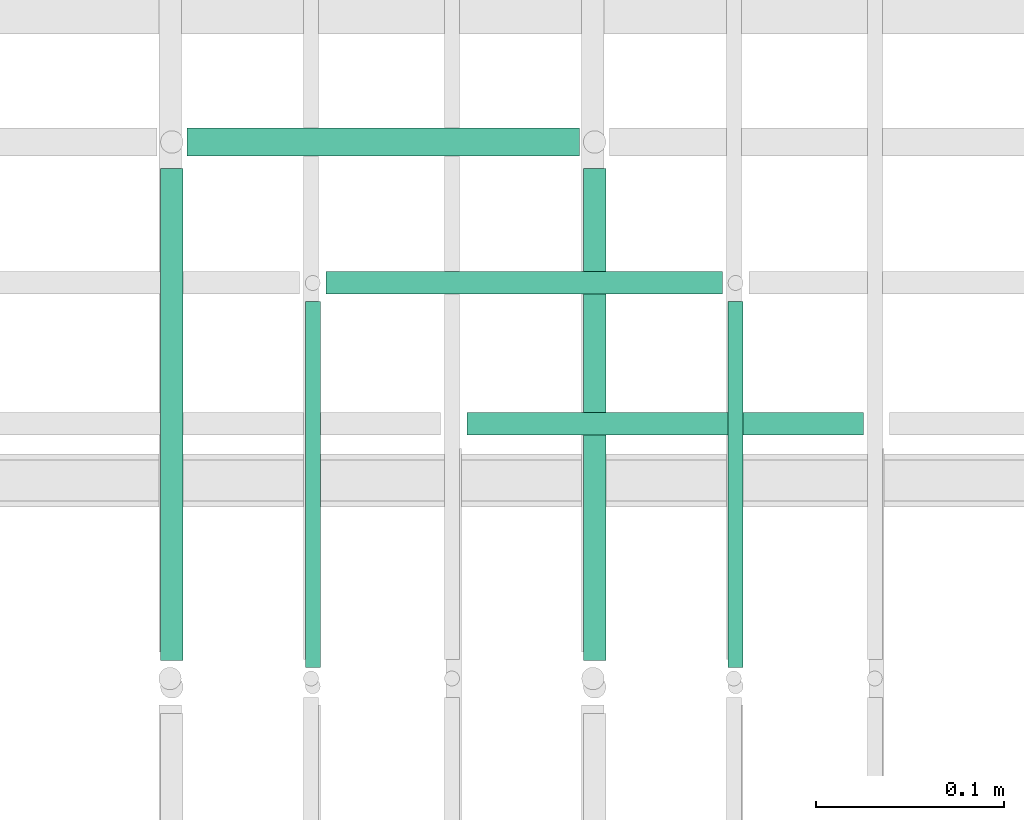
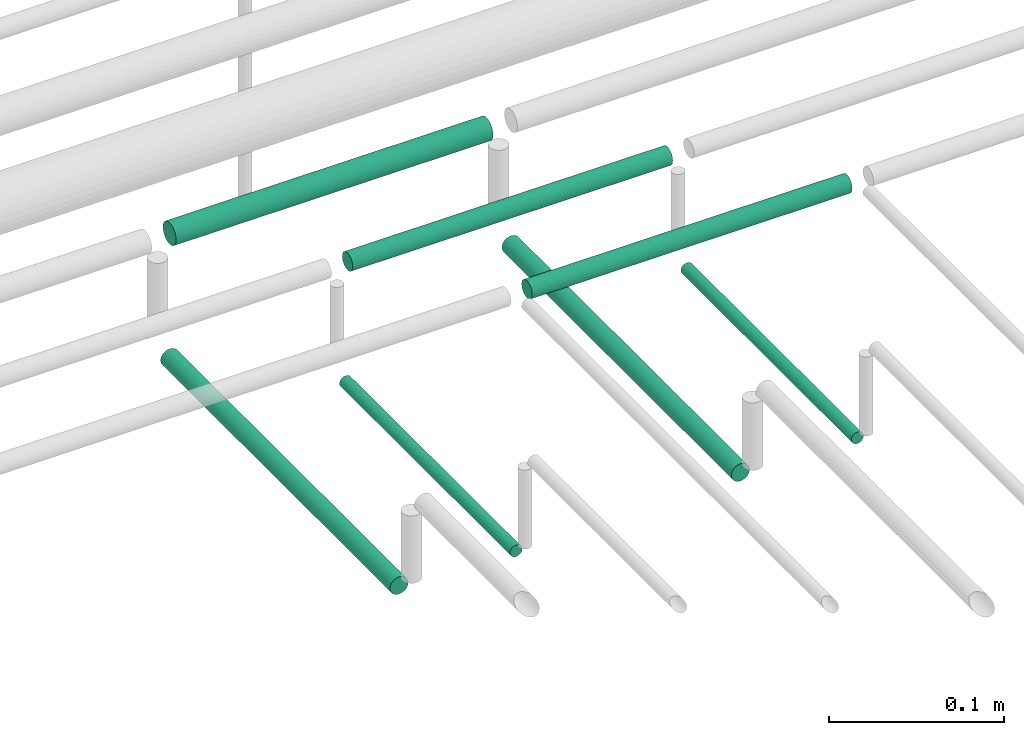
# One storey, part 200 of 331: 7 flow segments.
"""IFC2X3 building model written with IfcOpenShell, lengths in millimetres."""

import ifcopenshell
import ifcopenshell.guid

model = None  # the IFC model being written
_history = None  # IfcOwnerHistory: only IFC2X3 demands one
_inside = {}  # id of a spatial element -> (the spatial element, [elements in it])
_under = {}  # id of a project, library or spatial element -> (it, [spatial elements below it])
_declared = {}  # id of a project -> (the project, [libraries it declares])
_typed = {}  # id of a type object -> (the type object, [elements of that type])
_made_of = {}  # id of a material, layer set ... -> (it, [elements and type objects made of it])


def new_model(schema):
    """Start an empty IFC model of exactly this schema.

    Asked for "IFC4X3", IfcOpenShell would pick the latest addendum, in which some entities
    have other attributes; the version numbers below select the first issue.
    IFC2X3 requires an IfcOwnerHistory on every rooted entity: one is made here for all.
    """
    global model, _history
    if schema == "IFC4X3":
        model = ifcopenshell.file(schema_version=(4, 3, 0, 0))
    else:
        model = ifcopenshell.file(schema=schema)
    _inside.clear()
    _under.clear()
    _declared.clear()
    _typed.clear()
    _made_of.clear()
    _history = None
    if model.schema == "IFC2X3":
        org = make("IfcOrganization", Name="unknown")
        user = make(
            "IfcPersonAndOrganization",
            ThePerson=make("IfcPerson", FamilyName="unknown"),
            TheOrganization=org,
        )
        app = make(
            "IfcApplication",
            ApplicationDeveloper=org,
            Version="unknown",
            ApplicationFullName="unknown",
            ApplicationIdentifier="unknown",
        )
        _history = make(
            "IfcOwnerHistory",
            OwningUser=user,
            OwningApplication=app,
            ChangeAction="ADDED",
            CreationDate=0,
        )
    return model


def make(cls, **values):
    """One entity of the class cls with the attributes given. An attribute that is None is left unset."""
    return model.create_entity(
        cls, **{name: value for name, value in values.items() if value is not None}
    )


def entity(cls, *values):
    """Any entity or typed value of the class cls, its attributes in the order of the schema. None: left unset."""
    e = model.create_entity(cls)
    for i, value in enumerate(values):
        if value is not None:
            e[i] = value
    return e


def rooted(cls, **values):
    """An entity with a GlobalId (a new one), such as an element, a storey or a relation."""
    return make(cls, GlobalId=ifcopenshell.guid.new(), OwnerHistory=_history, **values)


def si_unit(unit_type, name, prefix=None):
    """IfcSIUnit, for example si_unit("LENGTHUNIT", "METRE", prefix="MILLI")."""
    return make("IfcSIUnit", UnitType=unit_type, Prefix=prefix, Name=name)


def converted_unit(unit_type, name, factor, base, dimensions=None, offset=None):
    """IfcConversionBasedUnit, such as the inch: factor (a typed value) times the base unit."""
    return make(
        "IfcConversionBasedUnit"
        if offset is None
        else "IfcConversionBasedUnitWithOffset",
        ConversionOffset=offset,
        Dimensions=None
        if dimensions is None
        else entity("IfcDimensionalExponents", *dimensions),
        UnitType=unit_type,
        Name=name,
        ConversionFactor=make(
            "IfcMeasureWithUnit", ValueComponent=factor, UnitComponent=base
        ),
    )


def derived_unit(unit_type, elements):
    """IfcDerivedUnit: a product of units, each with its exponent."""
    return make(
        "IfcDerivedUnit",
        Elements=[
            make("IfcDerivedUnitElement", Unit=unit, Exponent=power)
            for unit, power in elements
        ],
        UnitType=unit_type,
    )


def assignment(units):
    """IfcUnitAssignment: the units of a project."""
    return None if units is None else make("IfcUnitAssignment", Units=units)


def point(xyz):
    """IfcCartesianPoint."""
    return None if xyz is None else make("IfcCartesianPoint", Coordinates=xyz)


def direction(xyz):
    """IfcDirection."""
    return None if xyz is None else make("IfcDirection", DirectionRatios=xyz)


def frame(location, z_axis=None, x_axis=None):
    """IfcAxis2Placement3D, a coordinate frame: its origin and axes. An axis left out is left unset."""
    return make(
        "IfcAxis2Placement3D",
        Location=point(location),
        Axis=direction(z_axis),
        RefDirection=direction(x_axis),
    )


def frame_2d(location, x_axis=None):
    """IfcAxis2Placement2D, a coordinate frame in the plane: its origin and x axis."""
    return make(
        "IfcAxis2Placement2D", Location=point(location), RefDirection=direction(x_axis)
    )


def origin():
    """The frame at (0, 0, 0) with its axes left unset."""
    return frame((0.0, 0.0, 0.0))


def origin_2d_with_axis():
    """The frame at (0, 0) in the plane with the x axis (1, 0) written out."""
    return frame_2d((0.0, 0.0), x_axis=(1.0, 0.0))


def place(relative_to, where):
    """IfcLocalPlacement: puts the frame where relative to a parent placement (None: the world)."""
    return make(
        "IfcLocalPlacement", PlacementRelTo=relative_to, RelativePlacement=where
    )


def context(
    kind, dimensions, precision=None, world=None, true_north=None, identifier=None
):
    """IfcGeometricRepresentationContext, for example the 3D "Model" context."""
    return make(
        "IfcGeometricRepresentationContext",
        ContextIdentifier=identifier,
        ContextType=kind,
        CoordinateSpaceDimension=dimensions,
        Precision=precision,
        WorldCoordinateSystem=world,
        TrueNorth=true_north,
    )


def subcontext(parent, identifier, kind, view, scale=None):
    """IfcGeometricRepresentationSubContext, for example "Body" below "Model"."""
    return make(
        "IfcGeometricRepresentationSubContext",
        ContextIdentifier=identifier,
        ContextType=kind,
        ParentContext=parent,
        TargetScale=scale,
        TargetView=view,
    )


def project(units=None, contexts=None):
    """IfcProject with its units and contexts."""
    return rooted(
        "IfcProject",
        Name="project",
        RepresentationContexts=contexts,
        UnitsInContext=assignment(units),
    )


def spatial(cls, under=None, at=None, **own):
    """A site, building, storey or space (cls), placed at a placement, below another one or the project."""
    s = rooted(cls, ObjectPlacement=at, **own)
    if under is not None:
        _under.setdefault(under.id(), (under, []))[1].append(s)
    return s


def profile(cls, at=None, kind="AREA", **sizes):
    """A parametric profile (cls). Its sizes go by their IFC names, for example OverallWidth=200.0."""
    return make(cls, ProfileType=kind, Position=at, **sizes)


def circle(**sizes):
    """IfcCircleProfileDef."""
    return profile("IfcCircleProfileDef", **sizes)


def extrude(swept, where, along, depth):
    """IfcExtrudedAreaSolid: the profile swept, set in the frame where, extruded along a direction by depth."""
    return make(
        "IfcExtrudedAreaSolid",
        SweptArea=swept,
        Position=where,
        ExtrudedDirection=direction(along),
        Depth=depth,
    )


def shape(context_of_items, identifier, shape_type, items):
    """IfcShapeRepresentation: the items that make up one representation, for example the "Body"."""
    return make(
        "IfcShapeRepresentation",
        ContextOfItems=context_of_items,
        RepresentationIdentifier=identifier,
        RepresentationType=shape_type,
        Items=items,
    )


def made_of(thing, what):
    """Note that an element or type object is made of a material, layer set ...; save() writes the relation."""
    if what is not None:
        _made_of.setdefault(what.id(), (what, []))[1].append(thing)
    return thing


def type_object(cls, material=None, **own):
    """A type object (cls), such as IfcWallType, which elements share."""
    return made_of(rooted(cls, **own), material)


def element(
    cls,
    number,
    at=None,
    inside=None,
    cuts=None,
    type_object=None,
    material=None,
    context=None,
    identifier="Body",
    shape_type=None,
    held_by="IfcProductDefinitionShape",
    body=None,
    shapes=None,
    **own,
):
    """One element of the class cls, such as IfcWall. Its Tag is "e" and its number.

    at: its placement. inside: the storey or other place that contains it. cuts: it is an
    opening in that element (IfcRelVoidsElement). A single representation is given by context,
    identifier, shape_type and body (its items); several are given by shapes. held_by: the class
    of the entity that holds the representations. save() writes the other relations.
    """
    e = rooted(cls, Tag="e%d" % number, ObjectPlacement=at, **own)
    if body is not None:
        shapes = [shape(context, identifier, shape_type, body)]
    if shapes is not None:
        e.Representation = make(held_by, Representations=shapes)
    if inside is not None:
        _inside.setdefault(inside.id(), (inside, []))[1].append(e)
    if cuts is not None:
        rooted(
            "IfcRelVoidsElement", RelatingBuildingElement=cuts, RelatedOpeningElement=e
        )
    if type_object is not None:
        _typed.setdefault(type_object.id(), (type_object, []))[1].append(e)
    return made_of(e, material)


def aggregate(whole, parts):
    """IfcRelAggregates: a whole, such as a stair, and the parts it consists of."""
    return rooted("IfcRelAggregates", RelatingObject=whole, RelatedObjects=parts)


def save(model, path):
    """Write the relations noted so far, then the file.

    IfcRelAggregates (storeys below a building ...), IfcRelContainedInSpatialStructure (elements
    in a storey), IfcRelDefinesByType, IfcRelAssociatesMaterial and IfcRelDeclares: one each for
    every whole, place, type object, material and project.
    """
    for whole, parts in _under.values():
        aggregate(whole, parts)
    for where, things in _inside.values():
        rooted(
            "IfcRelContainedInSpatialStructure",
            RelatedElements=things,
            RelatingStructure=where,
        )
    for kind, things in _typed.values():
        rooted("IfcRelDefinesByType", RelatedObjects=things, RelatingType=kind)
    for what, things in _made_of.values():
        rooted("IfcRelAssociatesMaterial", RelatedObjects=things, RelatingMaterial=what)
    for by, libraries in _declared.values():
        rooted("IfcRelDeclares", RelatingContext=by, RelatedDefinitions=libraries)
    model.write(path)


model = new_model("IFC2X3")

# Units and contexts
model_context = context("Model", 3, precision=0.01, world=origin(), true_north=direction((6.12303176911189e-17, 1.0)))
body_context = subcontext(model_context, "Body", "Model", "MODEL_VIEW")
ifc_project = project(units=[si_unit("LENGTHUNIT", "METRE", prefix="MILLI"), si_unit("AREAUNIT", "SQUARE_METRE"), si_unit("VOLUMEUNIT", "CUBIC_METRE"), converted_unit("PLANEANGLEUNIT", "DEGREE", entity("IfcRatioMeasure", 0.0174532925199433), si_unit("PLANEANGLEUNIT", "RADIAN"), dimensions=[0, 0, 0, 0, 0, 0, 0]), si_unit("MASSUNIT", "GRAM", prefix="KILO"), derived_unit("MASSDENSITYUNIT", [(si_unit("MASSUNIT", "GRAM", prefix="KILO"), 1), (si_unit("LENGTHUNIT", "METRE"), -3)]), derived_unit("MOMENTOFINERTIAUNIT", [(si_unit("LENGTHUNIT", "METRE"), 4)]), si_unit("TIMEUNIT", "SECOND"), si_unit("FREQUENCYUNIT", "HERTZ"), si_unit("THERMODYNAMICTEMPERATUREUNIT", "DEGREE_CELSIUS"), derived_unit("THERMALTRANSMITTANCEUNIT", [(si_unit("MASSUNIT", "GRAM", prefix="KILO"), 1), (si_unit("THERMODYNAMICTEMPERATUREUNIT", "KELVIN"), -1), (si_unit("TIMEUNIT", "SECOND"), -3)]), derived_unit("VOLUMETRICFLOWRATEUNIT", [(si_unit("LENGTHUNIT", "METRE"), 3), (si_unit("TIMEUNIT", "SECOND"), -1)]), derived_unit("MASSFLOWRATEUNIT", [(si_unit("MASSUNIT", "GRAM", prefix="KILO"), 1), (si_unit("TIMEUNIT", "SECOND"), -1)]), derived_unit("ROTATIONALFREQUENCYUNIT", [(si_unit("TIMEUNIT", "SECOND"), -1)]), si_unit("ELECTRICCURRENTUNIT", "AMPERE"), si_unit("ELECTRICVOLTAGEUNIT", "VOLT"), si_unit("POWERUNIT", "WATT"), si_unit("FORCEUNIT", "NEWTON", prefix="KILO"), si_unit("ILLUMINANCEUNIT", "LUX"), si_unit("LUMINOUSFLUXUNIT", "LUMEN"), si_unit("LUMINOUSINTENSITYUNIT", "CANDELA"), derived_unit("USERDEFINED", [(si_unit("MASSUNIT", "GRAM", prefix="KILO"), -1), (si_unit("LENGTHUNIT", "METRE"), -2), (si_unit("TIMEUNIT", "SECOND"), 3), (si_unit("LUMINOUSFLUXUNIT", "LUMEN"), 1)]), derived_unit("LINEARVELOCITYUNIT", [(si_unit("LENGTHUNIT", "METRE"), 1), (si_unit("TIMEUNIT", "SECOND"), -1)]), si_unit("PRESSUREUNIT", "PASCAL"), derived_unit("USERDEFINED", [(si_unit("LENGTHUNIT", "METRE"), -2), (si_unit("MASSUNIT", "GRAM", prefix="KILO"), 1), (si_unit("TIMEUNIT", "SECOND"), -2)]), derived_unit("LINEARFORCEUNIT", [(si_unit("MASSUNIT", "GRAM", prefix="KILO"), 1), (si_unit("LENGTHUNIT", "METRE"), 1), (si_unit("TIMEUNIT", "SECOND"), -2), (si_unit("LENGTHUNIT", "METRE"), -1)]), derived_unit("PLANARFORCEUNIT", [(si_unit("MASSUNIT", "GRAM", prefix="KILO"), 1), (si_unit("LENGTHUNIT", "METRE"), 1), (si_unit("TIMEUNIT", "SECOND"), -2), (si_unit("LENGTHUNIT", "METRE"), -2)])], contexts=[model_context])

# Site, building, storey
site_placement = place(None, frame((0.0, -0.00077364408347762, 0.0)))
site = spatial("IfcSite", under=ifc_project, at=site_placement, CompositionType="ELEMENT")
building_placement = place(site_placement, origin())
building = spatial("IfcBuilding", under=site, at=building_placement, CompositionType="ELEMENT")
storey_placement = place(building_placement, origin())
storey = spatial("IfcBuildingStorey", under=building, at=storey_placement, CompositionType="ELEMENT", Elevation=0.0)

# Flow segments
pipe_segment_type = type_object("IfcPipeSegmentType", PredefinedType="NOTDEFINED")
for number, where in (
    (1, (53765.5223318378, 8096.00994384932, 14469.4047277641)),
    (2, (53990.5223318378, 8096.00994384932, 14469.4047277641)),
):
    element("IfcFlowSegment", number, at=place(storey_placement, frame(where)), inside=storey, type_object=pipe_segment_type, context=body_context, shape_type="SweptSolid", body=[
        extrude(circle(Radius=4.0, at=origin_2d_with_axis()), frame((5.59527223591499, 0.0, 5.59527223591499), z_axis=(0.0, 1.0, 0.0), x_axis=(1.0, 0.0, 0.0)), (0.0, 0.0, 1.0), 194.610619978047),
    ])
flow_segment_1_placement = place(storey_placement, frame((53688.5223318378, 8099.62056382737, 14467.4047277641)))
element("IfcFlowSegment", 3, at=flow_segment_1_placement, inside=storey, type_object=pipe_segment_type, context=body_context, shape_type="SweptSolid", body=[
    extrude(circle(Radius=6.0, at=origin_2d_with_axis()), frame((7.59527223591454, 0.0, 7.5952722359167), z_axis=(0.0, 1.0, 0.0), x_axis=(1.0, 0.0, 0.0)), (0.0, 0.0, 1.0), 261.999999999982),
])
flow_segment_2_placement = place(storey_placement, frame((53913.5223318378, 8099.62056382736, 14467.4047277641)))
element("IfcFlowSegment", 4, at=flow_segment_2_placement, inside=storey, type_object=pipe_segment_type, context=body_context, shape_type="SweptSolid", body=[
    extrude(circle(Radius=6.0, at=origin_2d_with_axis()), frame((7.59527223591454, 0.0, 7.5952722359167), z_axis=(0.0, 1.0, 0.0), x_axis=(1.0, 0.0, 0.0)), (0.0, 0.0, 1.0), 261.999999999998),
])
flow_segment_3_placement = place(storey_placement, frame((53853.1176040737, 8218.02529159143, 14542.4047277641)))
element("IfcFlowSegment", 5, at=flow_segment_3_placement, inside=storey, type_object=pipe_segment_type, context=body_context, shape_type="SweptSolid", body=[
    extrude(circle(Radius=6.0, at=frame_2d((-1.08286712929839e-12, 0.0), x_axis=(1.0, 0.0))), frame((0.0, 7.5952722359167, 7.5952722359167), z_axis=(1.0, 0.0, 0.0), x_axis=(0.0, -1.0, 0.0)), (0.0, 0.0, 1.0), 211.000000000013),
])
flow_segment_4_placement = place(storey_placement, frame((53778.1156082162, 8293.02529159145, 14542.5933778362)))
element("IfcFlowSegment", 6, at=flow_segment_4_placement, inside=storey, type_object=pipe_segment_type, context=body_context, shape_type="SweptSolid", body=[
    extrude(circle(Radius=6.0, at=frame_2d((0.0, -2.16573425811577e-12), x_axis=(1.0, 0.0))), frame((0.000126456651605622, 7.59527223591562, 7.59527223458044), z_axis=(1.0, 0.0, 2.10761091739803e-05), x_axis=(0.0, -1.0, 0.0)), (0.0, 0.0, 1.0), 210.999999949002),
])
flow_segment_5_placement = place(storey_placement, frame((53704.1155493392, 8366.52529159144, 14541.1057829606)))
element("IfcFlowSegment", 7, at=flow_segment_5_placement, inside=storey, type_object=pipe_segment_type, context=body_context, shape_type="SweptSolid", body=[
    extrude(circle(Radius=7.5, at=origin_2d_with_axis()), frame((0.000168554696574574, 9.09527223591636, 9.09527223402134), z_axis=(1.0, 0.0, 2.2473959014883e-05), x_axis=(0.0, -1.0, 0.0)), (0.0, 0.0, 1.0), 209.00000039833),
])

save(model, "model.ifc")
